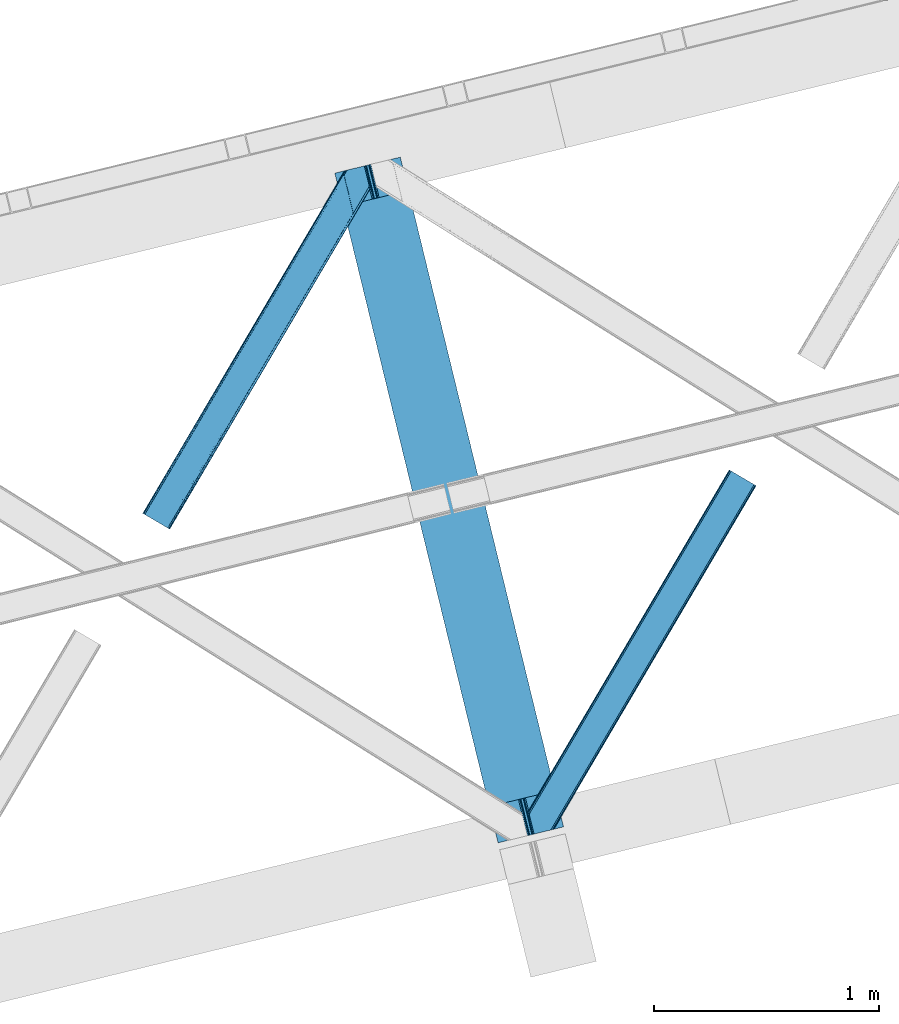
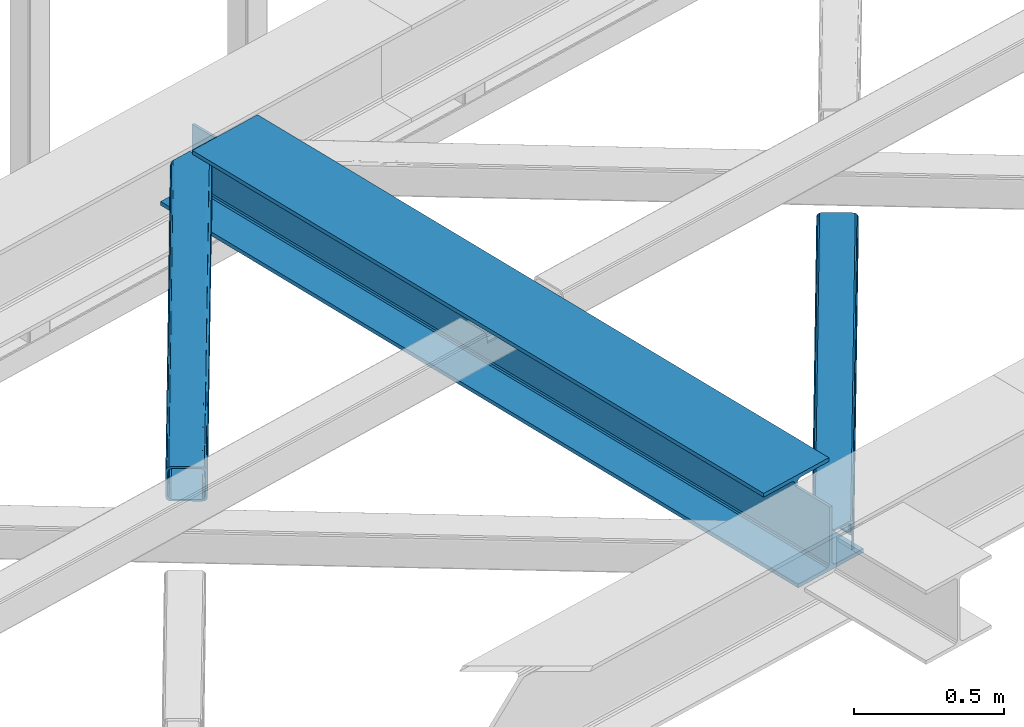
# One storey, part 23 of 66: 2 members, 1 beam.
"""IFC4 building model written with IfcOpenShell, lengths in millimetres."""

from ifc_helpers import new_model, entity, si_unit, converted_unit, derived_unit, direction, frame, origin, place, context, subcontext, project, spatial, triangles, polygons, material, type_object, element, save


model = new_model("IFC4")

# Units and contexts
model_context = context("Model", 3, precision=0.01, world=origin(), true_north=direction((6.12303176911189e-17, 1.0)))
plan_context = context("Plan", 3, precision=0.01, world=origin(), true_north=direction((6.12303176911189e-17, 1.0)))
body_context = subcontext(model_context, "Body", "Model", "MODEL_VIEW")
ifc_project = project(units=[si_unit("LENGTHUNIT", "METRE", prefix="MILLI"), si_unit("AREAUNIT", "SQUARE_METRE"), si_unit("VOLUMEUNIT", "CUBIC_METRE"), converted_unit("PLANEANGLEUNIT", "DEGREE", entity("IfcRatioMeasure", 0.0174532925199433), si_unit("PLANEANGLEUNIT", "RADIAN"), dimensions=[0, 0, 0, 0, 0, 0, 0]), si_unit("MASSUNIT", "GRAM", prefix="KILO"), derived_unit("MASSDENSITYUNIT", [(si_unit("MASSUNIT", "GRAM", prefix="KILO"), 1), (si_unit("LENGTHUNIT", "METRE"), -3)]), derived_unit("MOMENTOFINERTIAUNIT", [(si_unit("LENGTHUNIT", "METRE"), 4)]), si_unit("TIMEUNIT", "SECOND"), si_unit("FREQUENCYUNIT", "HERTZ"), si_unit("THERMODYNAMICTEMPERATUREUNIT", "DEGREE_CELSIUS"), derived_unit("THERMALTRANSMITTANCEUNIT", [(si_unit("MASSUNIT", "GRAM", prefix="KILO"), 1), (si_unit("THERMODYNAMICTEMPERATUREUNIT", "KELVIN"), -1), (si_unit("TIMEUNIT", "SECOND"), -3)]), derived_unit("VOLUMETRICFLOWRATEUNIT", [(si_unit("LENGTHUNIT", "METRE"), 3), (si_unit("TIMEUNIT", "SECOND"), -1)]), derived_unit("MASSFLOWRATEUNIT", [(si_unit("MASSUNIT", "GRAM", prefix="KILO"), 1), (si_unit("TIMEUNIT", "SECOND"), -1)]), derived_unit("ROTATIONALFREQUENCYUNIT", [(si_unit("TIMEUNIT", "SECOND"), -1)]), si_unit("ELECTRICCURRENTUNIT", "AMPERE"), si_unit("ELECTRICVOLTAGEUNIT", "VOLT"), si_unit("POWERUNIT", "WATT"), si_unit("FORCEUNIT", "NEWTON", prefix="KILO"), si_unit("ILLUMINANCEUNIT", "LUX"), si_unit("LUMINOUSFLUXUNIT", "LUMEN"), si_unit("LUMINOUSINTENSITYUNIT", "CANDELA"), derived_unit("USERDEFINED", [(si_unit("MASSUNIT", "GRAM", prefix="KILO"), -1), (si_unit("LENGTHUNIT", "METRE"), -2), (si_unit("TIMEUNIT", "SECOND"), 3), (si_unit("LUMINOUSFLUXUNIT", "LUMEN"), 1)]), derived_unit("LINEARVELOCITYUNIT", [(si_unit("LENGTHUNIT", "METRE"), 1), (si_unit("TIMEUNIT", "SECOND"), -1)]), si_unit("PRESSUREUNIT", "PASCAL"), derived_unit("USERDEFINED", [(si_unit("LENGTHUNIT", "METRE"), -2), (si_unit("MASSUNIT", "GRAM", prefix="KILO"), 1), (si_unit("TIMEUNIT", "SECOND"), -2)]), derived_unit("LINEARFORCEUNIT", [(si_unit("MASSUNIT", "GRAM", prefix="KILO"), 1), (si_unit("LENGTHUNIT", "METRE"), 1), (si_unit("TIMEUNIT", "SECOND"), -2), (si_unit("LENGTHUNIT", "METRE"), -1)]), derived_unit("PLANARFORCEUNIT", [(si_unit("MASSUNIT", "GRAM", prefix="KILO"), 1), (si_unit("LENGTHUNIT", "METRE"), 1), (si_unit("TIMEUNIT", "SECOND"), -2), (si_unit("LENGTHUNIT", "METRE"), -2)])], contexts=[model_context, plan_context])

# Site, building, storey
site_placement = place(None, origin())
site = spatial("IfcSite", under=ifc_project, at=site_placement, CompositionType="ELEMENT")
building_placement = place(site_placement, origin())
building = spatial("IfcBuilding", under=site, at=building_placement, CompositionType="ELEMENT")
storey_placement = place(building_placement, frame((0.0, 0.0, 19800.0)))
storey = spatial("IfcBuildingStorey", under=building, at=storey_placement, Name="06", CompositionType="ELEMENT", Elevation=19800.0)

# Beam
ifc_material = material(Name="Metal painted (White)")
beam_type = type_object("IfcBeamType", PredefinedType="BEAM")
beam_placement = place(storey_placement, frame((-52407.84, 5019.96, 3807.02)))
element("IfcBeam", 1, at=beam_placement, inside=storey, type_object=beam_type, material=ifc_material, ObjectType="Steel Beam", PredefinedType="BEAM", context=body_context, shape_type="Tessellation", body=[
    polygons([(1018.16648378329, 71.0478278971, 15.5000000000008), (1018.16648378329, 71.0478278971, 0.0), (291.465617442446, 3052.25531830421, 0.0), (291.465617442446, 3052.25531830421, 15.5000000000008), (894.779372399338, 40.970914087327, 15.5000000000008), (168.078506058482, 3022.17840449444, 15.5000000000008), (888.087028625384, 39.3395844888221, 16.8701684147984), (161.38616228452, 3020.54707489594, 16.8701684147984), (882.413533524751, 37.9566100336497, 20.7720779386434), (155.712667183895, 3019.16410044076, 20.7720779386434), (878.622625296184, 37.0325360459162, 26.6116982174294), (151.921758955338, 3018.24002645303, 26.6116982174294), (877.291435352779, 36.7080444135018, 33.500000000001), (150.590569011924, 3017.91553482061, 33.500000000001), (140.875048430514, 3015.54727389071, 33.500000000001), (140.875048430514, 3015.54727389071, 259.000000000002), (150.590569011932, 3017.91553482061, 259.000000000002), (-8.66293703438714e-12, 2981.20749040711, 0.0), (8.66293703438714e-12, 2981.20749040711, 15.4999999999965), (123.387111383964, 3011.28440421688, 15.5000000000008), (130.079455157926, 3012.91573381539, 16.8701684147984), (135.752950258542, 3014.29870827056, 20.7720779386434), (139.543858487117, 3015.2227822583, 26.6116982174294), (877.291435352779, 36.7080444135018, 259.000000000002), (867.575914771369, 34.3397834835981, 259.000000000002), (867.575914771369, 34.3397834835981, 33.500000000001), (866.244724827964, 34.0152918511827, 26.6116982174294), (862.453816599389, 33.0912178634492, 20.7720779386434), (856.780321498782, 31.7082434082767, 16.8701684147984), (850.087977724819, 30.0769138097719, 15.5000000000008), (726.700866340855, -1.08286712929839e-12, 15.4999999999965), (726.700866340855, -1.08286712929839e-12, 0.0), (838.124523615921, 197.385937999178, 259.069791973884), (186.469722099971, 2870.72539801218, 259.000000000002), (186.69311520182, 2869.80895360721, 259.617303331124), (186.705504045454, 2869.75812937344, 266.500003008253), (837.979344808147, 197.981416001702, 266.500002998871), (837.979694928899, 197.979979696967, 260.000004007589), (828.499586345876, 194.645865944428, 259.006343171919), (828.276216326111, 195.562317481909, 259.617303331124), (828.263827482477, 195.613141715681, 266.500003008253), (176.989986719784, 2867.38985508742, 266.500002998871), (176.98963659904, 2867.39129139215, 260.000004007589), (176.844830940696, 2867.98534020594, 259.07612046749), (176.754201518561, 2868.35713708228, 259.000000000002), (839.310832678066, 198.304685446387, 273.388305639783), (843.101109266762, 199.231350618301, 279.227924098781), (848.7741802143, 200.616065081978, 283.129832400619), (855.466371895425, 202.248018612791, 284.500000377228), (978.853400583278, 232.325271667903, 284.500000138971), (978.851730776618, 232.332121736635, 299.999995328161), (687.386308679347, 161.283492472592, 299.999995890962), (687.387978485999, 161.27664240386, 284.500000701776), (810.775007173852, 191.353895458972, 284.500000463519), (817.46749406999, 192.98463792555, 283.129832461069), (823.141405718742, 194.365903570075, 279.227924137322), (826.932940505742, 195.287407219373, 273.388305663684), (175.658498849857, 2867.06658564273, 273.388305639783), (171.868222261169, 2866.13992047082, 279.227924098781), (166.195151313631, 2864.75520600714, 283.129832400619), (159.502959632497, 2863.12325247633, 284.500000377228), (36.1159309446533, 2833.04599942122, 284.500000138971), (36.117600751305, 2833.03914935249, 299.999995328161), (327.583022848584, 2904.08777861653, 299.999995890962), (327.581353041932, 2904.09462868526, 284.500000701776), (204.194324354088, 2874.01737563015, 284.500000463519), (197.501837457941, 2872.38663316357, 283.129832461069), (191.827925809189, 2871.00536751905, 279.227924137322), (188.036391022189, 2870.08386386975, 273.388305663684)], [[[1, 2, 3, 4]], [[5, 1, 4, 6]], [[7, 5, 6, 8]], [[9, 7, 8, 10]], [[11, 9, 10, 12]], [[13, 11, 12, 14]], [[15, 16, 17, 14, 12, 10, 8, 6, 4, 3, 18, 19, 20, 21, 22, 23]], [[13, 24, 25, 26, 27, 28, 29, 30, 31, 32, 2, 1, 5, 7, 9, 11]], [[2, 32, 18, 3]], [[32, 31, 19, 18]], [[31, 30, 20, 19]], [[27, 26, 15, 23]], [[28, 27, 23, 22]], [[29, 28, 22, 21]], [[30, 29, 21, 20]], [[33, 24, 13, 14, 17, 34, 35, 36, 37, 38]], [[25, 39, 40, 41, 42, 43, 44, 16, 15, 26]], [[39, 25, 24, 33]], [[45, 34, 17, 16]], [[41, 40, 38, 37, 46, 47, 48, 49, 50, 51, 52, 53, 54, 55, 56, 57]], [[42, 58, 59, 60, 61, 62, 63, 64, 65, 66, 67, 68, 69, 36, 35, 43]], [[46, 37, 36, 69]], [[47, 46, 69, 68]], [[48, 47, 68, 67]], [[49, 48, 67, 66]], [[50, 49, 66, 65]], [[51, 50, 65, 64]], [[52, 51, 64, 63]], [[53, 52, 63, 62]], [[54, 53, 62, 61]], [[55, 54, 61, 60]], [[56, 55, 60, 59]], [[57, 56, 59, 58]], [[41, 57, 58, 42]]], closed=False),
])

# Members
member_type_1 = type_object("IfcMemberType", PredefinedType="BRACE")
member_1_placement = place(storey_placement, frame((-53262.93, 6415.95, 3824.0)))
element("IfcMember", 2, at=member_1_placement, inside=storey, type_object=member_type_1, ObjectType="Steel Horizontal Brace", PredefinedType="BRACE", context=body_context, shape_type="Tessellation", body=[
    triangles([(105.565649414064, 8.87852783203107, 0.0), (15.0781494140683, 62.148532104492, 0.0), (892.847827148442, 1346.13992614746, 0.0), (857.166284179693, 1492.50250396729, 0.0), (854.892004394533, 1501.83739929199, 1.33247680664135), (9.31105957031832, 65.5459991455082, 1.33247680664135), (852.961889648439, 1509.75145111084, 5.12526855468968), (4.4183349609375, 68.4266372680668, 5.12526855468968), (851.673596191409, 1515.03950042725, 10.8039916992202), (1.14876708984957, 70.3509384155277, 10.8039916992202), (851.222460937504, 1516.89636383057, 17.5012573242202), (0.0, 71.027059936524, 17.5012573242202), (893.633825683595, 1342.89826354981, 0.155804443358647), (111.332739257814, 5.48106079101581, 1.33247680664135), (899.559045410162, 1344.34178009033, 1.33247680664135), (912.390820312503, 1347.46949615479, 10.8039916992202), (914.195361328129, 1347.90958557129, 17.5012573242202), (120.643798828125, 0.0, 17.5012573242202), (119.495031738283, 0.675540161132631, 10.8039916992202), (907.251599121097, 1346.21666564941, 5.12526855468968), (116.225463867188, 2.60042266845721, 5.12526855468968), (902.493750000001, 1345.05743408203, 17.9802978515618), (893.633825683595, 1342.89826354981, 9.69243164062573), (897.768457031256, 1343.90459747315, 12.1248413085959), (903.721582031256, 1345.35683441162, 19.5011352539077), (914.195361328129, 1347.90958557129, 19.5011352539077), (1011.61732177735, 1513.38669433594, 19.5011352539077), (1008.98957519532, 1524.16103668213, 19.5011352539077), (1011.61732177735, 1513.38669433594, 122.499499511719), (120.643798828125, 0.0, 122.499499511719), (114.61160888672, 3.5515274047857, 24.5008300781265), (1009.23607177735, 1523.14423828125, 24.5008300781265), (113.462841796878, 4.22706756591833, 17.8035644531265), (110.193273925783, 6.15195007324201, 12.1248413085959), (105.300549316409, 9.03200683593786, 8.3320495605476), (99.52880859375, 12.4294738769531, 6.99957275390625), (892.685046386723, 1346.79976959229, 8.8831787109375), (890.466577148443, 1355.89747009277, 6.99957275390625), (21.1103393554731, 58.5975860595709, 6.99957275390625), (859.547534179692, 1482.74496002197, 6.99957275390625), (853.961828613283, 1505.66042175293, 18.501196289064), (851.222460937504, 1516.89636383057, 18.501196289064), (854.096704101568, 1505.10929260254, 17.8803039550803), (855.343139648438, 1499.99390716553, 12.1248413085959), (857.273254394531, 1492.07985534668, 8.3320495605476), (1009.23607177735, 1523.14423828125, 115.499926757813), (114.61160888672, 3.5515274047857, 115.499926757813), (1008.78493652344, 1525.00110168457, 122.197192382813), (113.462841796878, 4.22706756591833, 122.197192382813), (1007.49664306641, 1530.28915100098, 127.873590087893), (110.193273925783, 6.15195007324201, 127.873590087893), (1005.56652832031, 1538.20320281982, 131.668707275392), (105.300549316409, 9.03200683593786, 131.668707275392), (1003.29224853516, 1547.53809814453, 133.001184082033), (99.52880859375, 12.4294738769531, 133.001184082033), (851.952648925784, 1518.13291625977, 19.5011352539077), (854.575744628906, 1507.35857391357, 19.5011352539077), (851.780566406254, 1517.84049224854, 19.2639404296897), (854.426916503908, 1506.95045928955, 19.2592895507805), (851.585229492193, 1517.51434936523, 19.0011657714858), (854.268786621098, 1506.50920715332, 19.0011657714858), (851.394543457034, 1517.1887878418, 18.7360656738274), (854.110656738281, 1506.06853637695, 18.7407165527366), (908.014343261719, 1598.12687072754, 19.5011352539077), (897.540563964845, 1595.57411956787, 19.5011352539077), (1011.16618652344, 1515.24355773926, 129.196765136719), (1009.8732421875, 1520.53160705566, 134.87548828125), (1008.43146972657, 1526.45624542236, 138.000878906252), (986.307238769536, 1617.21175231934, 138.000878906252), (986.307238769536, 1617.21175231934, 133.001184082033), (897.540563964845, 1595.57411956787, 122.499499511719), (0.0, 71.027059936524, 122.499499511719), (7.18095703125437, 66.7999923706057, 17.8035644531265), (10.4505249023496, 64.8751098632811, 12.1248413085959), (6.03218994141207, 67.4755325317383, 24.5008300781265), (907.023706054693, 1597.88560638428, 24.5008300781265), (15.3432495117231, 61.9944717407225, 8.3320495605476), (908.832897949222, 1598.32569580078, 122.197192382813), (899.345104980472, 1596.01362762451, 129.196765136719), (904.484326171878, 1597.26645812988, 134.87548828125), (930.73388671875, 1603.66548614502, 133.001184082033), (910.246765136719, 1598.67044219971, 138.000878906252), (921.664672851563, 1601.45341186523, 131.668707275392), (913.972119140628, 1599.57852630615, 127.873590087893), (907.023706054693, 1597.88560638428, 115.499926757813), (21.1103393554731, 58.5975860595709, 133.001184082033), (6.03218994141207, 67.4755325317383, 115.499926757813), (15.3432495117231, 61.9944717407225, 131.668707275392), (10.4505249023496, 64.8751098632811, 127.873590087893), (7.18095703125437, 66.7999923706057, 122.197192382813), (119.495031738283, 0.675540161132631, 129.196765136719), (116.225463867188, 2.60042266845721, 134.87548828125), (111.332739257814, 5.48106079101581, 138.668280029298), (105.565649414064, 8.87852783203107, 140.00075683594), (15.0781494140683, 62.148532104492, 140.00075683594), (9.31105957031832, 65.5459991455082, 138.668280029298), (4.4183349609375, 68.4266372680668, 134.87548828125), (1.14876708984957, 70.3509384155277, 129.196765136719), (896.991760253906, 1576.15611877441, 138.000878906252), (938.18924560547, 1407.14434204102, 138.000878906252), (899.024194335943, 1563.59525756836, 140.00075683594), (897.042919921878, 1571.72266845703, 139.000817871096), (896.796423339845, 1573.13711700439, 138.638049316407), (896.926647949222, 1575.15443572998, 138.212493896484), (896.861535644537, 1574.14170684815, 138.426434326171), (937.473010253911, 1407.08562469482, 138.293884277344), (937.077685546879, 1408.09486541748, 138.647351074218), (936.682360839848, 1409.10410614014, 139.000817871096), (934.701086425783, 1417.23267974854, 140.00075683594)], [[1, 2, 3], [4, 3, 2], [5, 4, 6], [2, 6, 4], [7, 5, 8], [6, 8, 5], [9, 7, 10], [8, 10, 7], [11, 9, 12], [10, 12, 9], [1, 3, 13], [13, 14, 1], [13, 15, 14], [16, 17, 18], [18, 19, 16], [20, 16, 19], [19, 21, 20], [15, 20, 21], [21, 14, 15], [20, 22, 16], [23, 24, 15], [23, 15, 13], [15, 24, 20], [16, 25, 17], [20, 24, 22], [16, 22, 25], [26, 17, 25], [26, 25, 27], [28, 27, 25], [27, 29, 26], [30, 26, 29], [26, 18, 17], [30, 18, 26], [31, 32, 25], [25, 33, 31], [25, 22, 33], [32, 28, 25], [33, 22, 24], [34, 24, 23], [23, 35, 34], [36, 35, 37], [37, 38, 36], [23, 37, 35], [24, 34, 33], [39, 36, 38], [38, 40, 39], [9, 11, 41], [11, 42, 41], [43, 9, 41], [43, 7, 9], [44, 7, 43], [5, 44, 45], [44, 5, 7], [4, 5, 45], [45, 40, 4], [37, 23, 13], [37, 3, 38], [3, 40, 38], [40, 3, 4], [37, 13, 3], [46, 32, 31], [31, 47, 46], [48, 46, 49], [47, 49, 46], [50, 48, 51], [49, 51, 48], [52, 50, 53], [51, 53, 50], [54, 52, 55], [53, 55, 52], [56, 57, 58], [59, 58, 57], [58, 59, 60], [61, 60, 59], [60, 61, 62], [63, 62, 61], [62, 63, 42], [41, 42, 63], [57, 56, 64], [65, 64, 56], [66, 48, 67], [46, 29, 27], [27, 32, 46], [32, 27, 28], [48, 29, 46], [66, 29, 48], [50, 68, 67], [52, 68, 50], [67, 48, 50], [52, 54, 68], [54, 69, 68], [70, 69, 54], [71, 60, 62], [58, 60, 71], [71, 56, 58], [56, 71, 65], [42, 12, 72], [12, 42, 11], [71, 42, 72], [42, 71, 62], [73, 74, 44], [75, 73, 43], [43, 41, 75], [43, 57, 75], [64, 76, 57], [75, 57, 76], [44, 43, 73], [45, 44, 74], [74, 77, 45], [40, 45, 77], [77, 39, 40], [78, 79, 80], [81, 82, 69], [69, 70, 81], [81, 83, 82], [84, 82, 83], [80, 82, 84], [78, 71, 79], [85, 71, 78], [80, 84, 78], [65, 76, 64], [85, 65, 71], [76, 65, 85], [86, 54, 55], [54, 86, 81], [70, 54, 81], [76, 85, 87], [87, 75, 76], [83, 81, 86], [86, 88, 83], [84, 83, 88], [88, 89, 84], [78, 84, 89], [89, 90, 78], [85, 78, 90], [90, 87, 85], [91, 51, 49], [47, 18, 30], [91, 49, 30], [91, 92, 51], [49, 47, 30], [51, 92, 93], [55, 94, 95], [94, 53, 93], [53, 94, 55], [53, 51, 93], [19, 34, 21], [31, 18, 47], [18, 33, 19], [33, 18, 31], [19, 33, 34], [1, 36, 2], [14, 21, 34], [34, 35, 14], [35, 36, 1], [1, 14, 35], [89, 96, 97], [95, 86, 55], [95, 88, 86], [88, 95, 96], [89, 88, 96], [87, 72, 12], [98, 90, 89], [97, 98, 89], [90, 98, 72], [87, 90, 72], [6, 74, 8], [2, 36, 39], [39, 77, 2], [77, 74, 6], [6, 2, 77], [10, 8, 74], [12, 75, 87], [73, 12, 10], [12, 73, 75], [73, 10, 74], [99, 68, 82], [99, 100, 68], [68, 69, 82], [96, 95, 101], [101, 102, 96], [97, 96, 103], [104, 97, 105], [104, 99, 97], [97, 103, 105], [82, 80, 99], [97, 99, 80], [102, 103, 96], [79, 71, 98], [72, 98, 71], [80, 79, 97], [98, 97, 79], [92, 67, 100], [100, 93, 92], [67, 68, 100], [106, 107, 93], [94, 93, 107], [107, 108, 94], [108, 109, 94], [66, 67, 92], [92, 91, 66], [29, 66, 91], [91, 30, 29], [95, 94, 109], [109, 101, 95], [107, 103, 102], [105, 103, 107], [106, 104, 105], [100, 99, 104], [107, 106, 105], [102, 108, 107], [102, 101, 109], [109, 108, 102]]),
])
member_type_2 = type_object("IfcMemberType", PredefinedType="BRACE")
member_2_placement = place(storey_placement, frame((-51546.08, 5059.05, 3824.0)))
element("IfcMember", 3, at=member_2_placement, inside=storey, type_object=member_type_2, ObjectType="Steel Horizontal Brace", PredefinedType="BRACE", context=body_context, shape_type="Tessellation", body=[
    triangles([(154.446386718751, 124.70924835205, 0.0), (118.769494628912, 271.071826171875, 0.0), (998.971582031256, 1559.19901428223, 0.0), (908.484082031253, 1612.46901855469, 0.0), (1004.73867187501, 1555.80154724121, 1.33247680664135), (156.720666503912, 115.37377166748, 1.33247680664135), (1009.63604736328, 1552.92090911865, 5.12526855468968), (158.650781250006, 107.459719848633, 5.12526855468968), (1012.90096435547, 1550.99602661133, 10.8039916992202), (159.939074707036, 102.17225189209, 10.8039916992202), (1014.04973144532, 1550.32048645019, 17.5012573242202), (160.39020996094, 100.315388488769, 17.5012573242202), (902.716992187503, 1615.8664855957, 1.33247680664135), (116.495214843751, 280.406721496582, 1.33247680664135), (114.574401855469, 288.276008605957, 5.1694519042976), (897.824267578129, 1618.74712371826, 5.12526855468968), (114.495336914064, 288.596919250488, 5.32758178711083), (894.554699707034, 1620.67142486572, 10.8039916992202), (109.625866699222, 287.409201049804, 10.8039916992202), (893.405932617192, 1621.34754638672, 17.5012573242202), (107.821325683595, 286.969692993163, 17.5012573242202), (113.523303222661, 288.360305786133, 18.5197998046897), (114.495336914064, 288.596919250488, 17.5198608398459), (114.420922851568, 288.578897094726, 17.9035583496116), (114.211633300787, 288.527737426757, 18.2267944335945), (113.895373535161, 288.450416564941, 18.4453857421868), (107.821325683595, 286.969692993163, 18.5197998046897), (115.695263671878, 283.683847045898, 17.5198608398459), (115.625500488284, 283.800700378418, 17.8035644531265), (115.565039062501, 283.7408203125, 17.8570495605491), (115.318542480469, 283.496067810058, 18.0779663085959), (115.067395019534, 283.239688110351, 18.3081848144539), (114.830200195313, 283.003656005859, 18.5197998046897), (0.0, 103.825057983398, 18.5197998046897), (2.73471679687646, 92.5989990234375, 18.5197998046897), (893.405932617192, 1621.34754638672, 122.499499511719), (0.0, 103.825057983398, 122.499499511719), (908.484082031253, 1612.46901855469, 140.00075683594), (902.716992187503, 1615.8664855957, 138.668280029298), (3.66954345703562, 88.766093444824, 138.668280029298), (5.94382324218896, 79.4311981201172, 140.00075683594), (897.824267578129, 1618.74712371826, 134.87548828125), (1.73942871094187, 96.6801452636719, 134.87548828125), (894.554699707034, 1620.67142486572, 129.196765136719), (0.451135253912071, 101.968194580078, 129.196765136719), (899.438122558597, 1617.79601898193, 24.5008300781265), (2.37659912109666, 94.0675140380854, 24.5008300781265), (900.586889648439, 1617.1204788208, 17.8035644531265), (903.856457519534, 1615.19559631348, 12.1248413085959), (914.516271972658, 1608.9174911499, 6.99957275390625), (908.749182128908, 1612.31553955078, 8.3320495605476), (118.871813964848, 270.64917755127, 8.3320495605476), (121.146093750001, 261.314282226562, 6.99957275390625), (116.941699218754, 278.563229370116, 12.1248413085959), (152.069787597662, 134.466792297363, 6.99957275390625), (992.939392089844, 1562.75054168701, 6.99957275390625), (156.274182128909, 117.217263793945, 12.1248413085959), (154.344067382815, 125.131315612793, 8.3320495605476), (157.520617675786, 112.097227478027, 17.5198608398459), (160.39020996094, 100.315388488769, 17.5198608398459), (899.438122558597, 1617.79601898193, 115.499926757813), (2.37659912109666, 94.0675140380854, 115.499926757813), (900.586889648439, 1617.1204788208, 122.197192382813), (2.82773437500146, 92.2106506347654, 122.197192382813), (903.856457519534, 1615.19559631348, 127.873590087893), (4.12067871094041, 86.9226013183588, 127.873590087893), (908.749182128908, 1612.31553955078, 131.668707275392), (6.046142578125, 79.008549499511, 131.668707275392), (914.516271972658, 1608.9174911499, 133.001184082033), (8.3250732421875, 69.6736541748041, 133.001184082033), (25.3054321289092, 0.0, 133.001184082033), (25.3054321289092, 0.0, 140.00075683594), (90.3619262695356, 15.8583343505852, 140.00075683594), (998.971582031256, 1559.19901428223, 140.00075683594), (1014.04973144532, 1550.32048645019, 122.499499511719), (1012.90096435547, 1550.99602661133, 129.196765136719), (114.0721069336, 21.6382141113281, 122.499499511719), (112.267565917973, 21.1981246948235, 129.196765136719), (1009.63604736328, 1552.92090911865, 134.87548828125), (107.128344726567, 19.9452941894524, 134.87548828125), (1004.73867187501, 1555.80154724121, 138.668280029298), (99.435791015625, 18.0698272705076, 138.668280029298), (159.664672851563, 99.0788360595698, 18.5197998046897), (114.0721069336, 21.6382141113281, 18.5197998046897), (103.161145019534, 18.9784927368164, 18.5197998046897), (156.929956054693, 110.304895019531, 18.5197998046897), (1008.01754150391, 1553.87201385498, 24.5008300781265), (1006.86877441406, 1554.54755401611, 17.8035644531265), (157.222961425781, 111.200770568847, 18.0198303222678), (1003.60385742188, 1556.47243652344, 12.1248413085959), (998.706481933594, 1559.35249328613, 8.3320495605476), (104.588964843751, 19.3261459350579, 24.5008300781265), (1003.60385742188, 1556.47243652344, 127.873590087893), (1008.01754150391, 1553.87201385498, 115.499926757813), (1006.86877441406, 1554.54755401611, 122.197192382813), (992.939392089844, 1562.75054168701, 133.001184082033), (998.706481933594, 1559.35249328613, 131.668707275392), (102.784423828125, 18.8860565185541, 122.197192382813), (80.8787841796875, 13.5468475341795, 133.001184082033), (89.9526489257842, 15.758340454101, 131.668707275392), (97.6452026367188, 17.633226013183, 127.873590087893), (104.588964843751, 19.3261459350579, 115.499926757813)], [[1, 2, 3], [4, 3, 2], [3, 5, 1], [6, 1, 5], [5, 7, 6], [8, 6, 7], [7, 9, 8], [10, 8, 9], [9, 11, 10], [12, 10, 11], [13, 14, 15], [16, 15, 17], [17, 18, 16], [17, 19, 18], [20, 18, 19], [19, 21, 20], [15, 16, 13], [13, 4, 14], [2, 14, 4], [22, 23, 24], [22, 25, 26], [27, 21, 22], [24, 25, 22], [23, 22, 21], [21, 19, 23], [17, 23, 19], [23, 28, 29], [29, 24, 23], [25, 24, 30], [26, 25, 31], [22, 26, 32], [32, 33, 22], [31, 32, 26], [30, 31, 25], [29, 30, 24], [34, 33, 35], [33, 34, 27], [22, 33, 27], [27, 20, 21], [36, 27, 37], [27, 36, 20], [27, 34, 37], [38, 39, 40], [40, 41, 38], [39, 42, 43], [43, 40, 39], [42, 44, 45], [45, 43, 42], [44, 36, 37], [37, 45, 44], [46, 47, 33], [33, 48, 46], [33, 31, 48], [47, 35, 33], [49, 48, 28], [50, 51, 52], [52, 53, 50], [51, 49, 54], [54, 52, 51], [28, 54, 49], [53, 55, 56], [56, 50, 53], [55, 2, 1], [54, 17, 14], [52, 14, 2], [52, 2, 53], [55, 53, 2], [17, 28, 23], [54, 28, 17], [52, 54, 14], [57, 58, 6], [58, 1, 6], [1, 58, 55], [8, 57, 6], [8, 59, 57], [10, 59, 8], [10, 60, 59], [46, 61, 47], [62, 47, 61], [61, 63, 62], [64, 62, 63], [63, 65, 64], [66, 64, 65], [65, 67, 66], [68, 66, 67], [67, 69, 68], [70, 68, 69], [66, 43, 64], [71, 72, 70], [72, 41, 70], [40, 68, 41], [66, 68, 40], [68, 70, 41], [66, 40, 43], [37, 34, 62], [45, 64, 43], [62, 64, 37], [64, 45, 37], [34, 47, 62], [34, 35, 47], [41, 73, 74], [73, 41, 72], [74, 38, 41], [75, 76, 77], [78, 77, 76], [76, 79, 78], [80, 78, 79], [79, 81, 80], [82, 80, 81], [81, 74, 82], [73, 82, 74], [60, 75, 77], [60, 11, 75], [77, 83, 60], [77, 84, 83], [84, 85, 83], [86, 83, 85], [87, 88, 59], [89, 86, 87], [88, 90, 57], [57, 59, 88], [90, 91, 58], [58, 57, 90], [91, 56, 55], [55, 58, 91], [87, 86, 92], [85, 92, 86], [9, 90, 88], [87, 75, 11], [9, 88, 11], [9, 7, 90], [88, 87, 11], [90, 7, 5], [56, 3, 4], [3, 91, 5], [91, 3, 56], [91, 90, 5], [76, 93, 79], [94, 75, 87], [75, 95, 76], [95, 75, 94], [76, 95, 93], [74, 96, 38], [81, 79, 93], [93, 97, 81], [97, 96, 74], [74, 81, 97], [49, 13, 16], [4, 50, 56], [4, 51, 50], [51, 4, 13], [49, 51, 13], [46, 20, 36], [18, 48, 49], [16, 18, 49], [48, 18, 20], [46, 48, 20], [39, 65, 42], [38, 96, 69], [69, 67, 38], [67, 65, 39], [39, 38, 67], [44, 42, 65], [36, 61, 46], [63, 36, 44], [36, 63, 61], [63, 44, 65], [98, 78, 80], [99, 73, 72], [72, 71, 99], [99, 100, 73], [100, 82, 73], [101, 82, 100], [80, 82, 101], [98, 77, 78], [102, 77, 98], [80, 101, 98], [84, 92, 85], [102, 84, 77], [92, 84, 102], [99, 70, 96], [99, 71, 70], [69, 96, 70], [96, 97, 100], [100, 99, 96], [97, 93, 101], [101, 100, 97], [93, 95, 98], [98, 101, 93], [95, 94, 102], [102, 98, 95], [94, 87, 92], [92, 102, 94]]),
])

save(model, "model.ifc")
